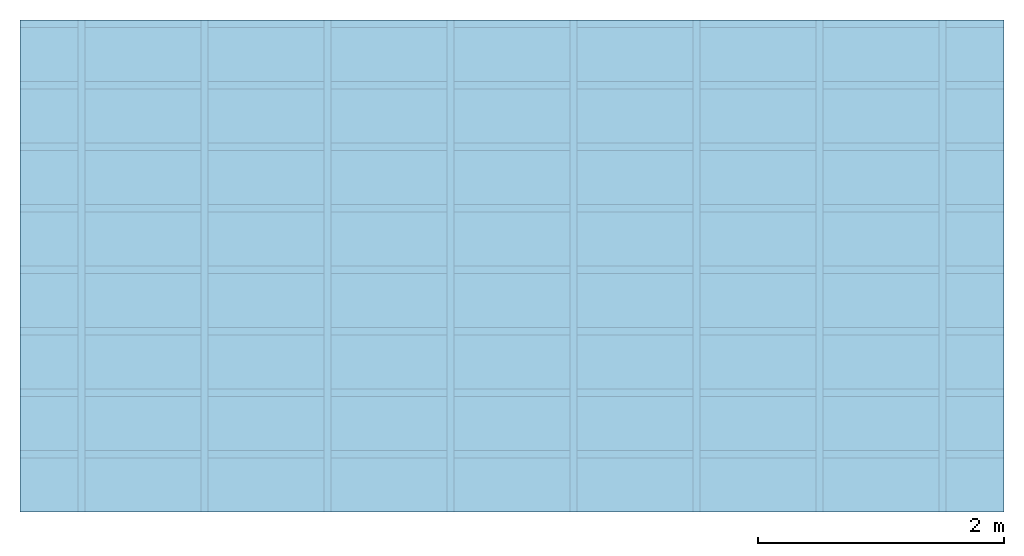
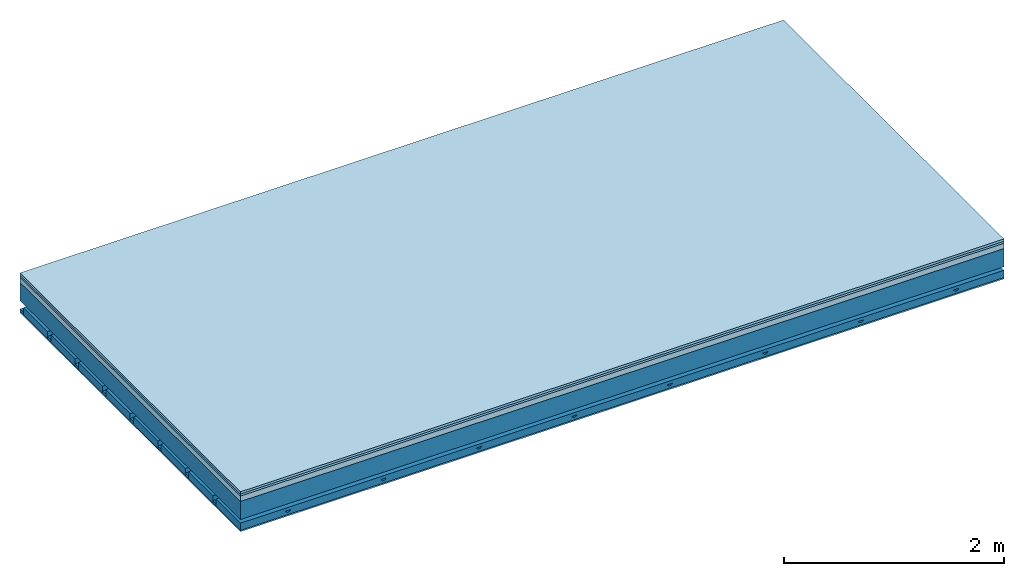
# One storey: 4 members, 4 plates, 1 element without a shape of its own.
"""IFC4 building model written with IfcOpenShell, lengths in metres."""

from ifc_helpers import new_model, si_unit, derived_unit, direction, frame, frame_2d, origin, origin_with_axes, place, context, project, spatial, polyline, rectangle, outline, extrude, material, layer, layer_set, type_object, element, aggregate, save


model = new_model("IFC4")

# Units and contexts
plan_context = context("Plan", 3, precision=1e-05, world=origin(), true_north=direction((0.0, 1.0)))
model_context = context("Model", 3, precision=1e-05, world=origin(), true_north=direction((0.0, 1.0)))
ifc_project = project(units=[si_unit("LENGTHUNIT", "METRE"), derived_unit("SOUNDPRESSUREUNIT", [(si_unit("PRESSUREUNIT", "PASCAL", prefix="MICRO"), 0)]), si_unit("ENERGYUNIT", "JOULE", prefix="MEGA"), si_unit("MASSUNIT", "GRAM", prefix="KILO"), derived_unit("THERMALTRANSMITTANCEUNIT", [(si_unit("POWERUNIT", "WATT"), 1), (si_unit("AREAUNIT", "SQUARE_METRE"), -1), (si_unit("THERMODYNAMICTEMPERATUREUNIT", "KELVIN"), -1)]), derived_unit("AREADENSITYUNIT", [(si_unit("MASSUNIT", "GRAM", prefix="KILO"), 1), (si_unit("AREAUNIT", "SQUARE_METRE"), -1)]), derived_unit("USERDEFINED", [(si_unit("ENERGYUNIT", "JOULE", prefix="MEGA"), 1), (si_unit("AREAUNIT", "SQUARE_METRE"), -1)])], contexts=[plan_context, model_context])

# Site, building, storey
site = spatial("IfcSite", under=ifc_project)
building_placement = place(None, origin())
building = spatial("IfcBuilding", under=site, at=building_placement)
storey_placement = place(building_placement, origin())
storey = spatial("IfcBuildingStorey", under=building, at=storey_placement)

# Slab, members, plates
ifc_material_1 = material(Name="Floor heating system Therm38 longitudinal", Category="03.007")
ifc_layer_1 = layer(ifc_material_1, 0.025, Name="On-material")
ifc_material_2 = material(Category="10.009")
ifc_layer_2 = layer(ifc_material_2, 0.022, Name="Impact sound insulation")
ifc_material_3 = material(Category="03.011")
ifc_layer_3 = layer(ifc_material_3, 0.06, Name="on Supporting structure")
ifc_layer_4 = layer(None, 0.2, Name="Supporting structure")
ifc_material_4 = material(Name="no composite action")
ifc_layer_5 = layer(ifc_material_4, 0.0, Name="Bond")
ifc_layer_6 = layer(None, 0.093, Name="Coupling")
ifc_layer_7 = layer(None, 0.027, Name="Battens / profiles")
ifc_material_5 = material(Category="03.007")
ifc_layer_8 = layer(ifc_material_5, 0.015, Name="Ceiling covering 1st layer")
ifc_material_6 = material(Name="Glued joints")
ifc_layer_9 = layer(ifc_material_6, 0.0, Name="Surface / treatment")
ifc_layer_set = layer_set([ifc_layer_1, ifc_layer_2, ifc_layer_3, ifc_layer_4, ifc_layer_5, ifc_layer_6, ifc_layer_7, ifc_layer_8, ifc_layer_9])
slab_type = type_object("IfcSlabType", Name="A1156", PredefinedType="NOTDEFINED", material=ifc_layer_set)
slab_placement = place(None, frame((0.0, 0.0, 0.0), z_axis=(0.0, 0.0, -1.0), x_axis=(1.0, 0.0, 0.0)))
slab = element("IfcSlab", 1, at=slab_placement, inside=storey, type_object=slab_type, material=ifc_layer_set, Name="Slab #1")
ifc_material_7 = material()
member_1_placement = place(slab_placement, origin())
member_1 = element("IfcMember", 2, at=member_1_placement, material=ifc_material_7, Name="Supporting structure", context=plan_context, shape_type="SweptSolid", body=[
    extrude(rectangle(XDim=1.0, YDim=0.2, at=frame_2d((0.5, 0.1), x_axis=(1.0, 0.0))), frame((0.0, 4.0, 0.107), z_axis=(0.0, -1.0, 0.0), x_axis=(1.0, 0.0, 0.0)), (0.0, 0.0, 1.0), 4.0),
    extrude(rectangle(XDim=1.0, YDim=0.2, at=frame_2d((0.5, 0.1), x_axis=(1.0, 0.0))), frame((1.0, 4.0, 0.107), z_axis=(0.0, -1.0, 0.0), x_axis=(1.0, 0.0, 0.0)), (0.0, 0.0, 1.0), 4.0),
    extrude(rectangle(XDim=1.0, YDim=0.2, at=frame_2d((0.5, 0.1), x_axis=(1.0, 0.0))), frame((2.0, 4.0, 0.107), z_axis=(0.0, -1.0, 0.0), x_axis=(1.0, 0.0, 0.0)), (0.0, 0.0, 1.0), 4.0),
    extrude(rectangle(XDim=1.0, YDim=0.2, at=frame_2d((0.5, 0.1), x_axis=(1.0, 0.0))), frame((3.0, 4.0, 0.107), z_axis=(0.0, -1.0, 0.0), x_axis=(1.0, 0.0, 0.0)), (0.0, 0.0, 1.0), 4.0),
    extrude(rectangle(XDim=1.0, YDim=0.2, at=frame_2d((0.5, 0.1), x_axis=(1.0, 0.0))), frame((4.0, 4.0, 0.107), z_axis=(0.0, -1.0, 0.0), x_axis=(1.0, 0.0, 0.0)), (0.0, 0.0, 1.0), 4.0),
    extrude(rectangle(XDim=1.0, YDim=0.2, at=frame_2d((0.5, 0.1), x_axis=(1.0, 0.0))), frame((5.0, 4.0, 0.107), z_axis=(0.0, -1.0, 0.0), x_axis=(1.0, 0.0, 0.0)), (0.0, 0.0, 1.0), 4.0),
    extrude(rectangle(XDim=1.0, YDim=0.2, at=frame_2d((0.5, 0.1), x_axis=(1.0, 0.0))), frame((6.0, 4.0, 0.107), z_axis=(0.0, -1.0, 0.0), x_axis=(1.0, 0.0, 0.0)), (0.0, 0.0, 1.0), 4.0),
    extrude(rectangle(XDim=1.0, YDim=0.2, at=frame_2d((0.5, 0.1), x_axis=(1.0, 0.0))), frame((7.0, 4.0, 0.107), z_axis=(0.0, -1.0, 0.0), x_axis=(1.0, 0.0, 0.0)), (0.0, 0.0, 1.0), 4.0),
])
ifc_material_8 = material()
member_2_placement = place(slab_placement, origin())
member_2 = element("IfcMember", 3, at=member_2_placement, material=ifc_material_8, Name="Coupling", context=plan_context, shape_type="SweptSolid", body=[
    extrude(outline(polyline([(0.0, 0.0), (0.06, 0.0), (0.04, 0.02), (0.02, 0.02), (0.0, 0.0)])), frame((0.47, 4.0, 0.38), z_axis=(0.0, -1.0, 0.0), x_axis=(1.0, 0.0, 0.0)), (0.0, 0.0, 1.0), 4.0),
    extrude(outline(polyline([(0.0, 0.0), (0.06, 0.0), (0.04, 0.02), (0.02, 0.02), (0.0, 0.0)])), frame((1.47, 4.0, 0.38), z_axis=(0.0, -1.0, 0.0), x_axis=(1.0, 0.0, 0.0)), (0.0, 0.0, 1.0), 4.0),
    extrude(outline(polyline([(0.0, 0.0), (0.06, 0.0), (0.04, 0.02), (0.02, 0.02), (0.0, 0.0)])), frame((2.47, 4.0, 0.38), z_axis=(0.0, -1.0, 0.0), x_axis=(1.0, 0.0, 0.0)), (0.0, 0.0, 1.0), 4.0),
    extrude(outline(polyline([(0.0, 0.0), (0.06, 0.0), (0.04, 0.02), (0.02, 0.02), (0.0, 0.0)])), frame((3.47, 4.0, 0.38), z_axis=(0.0, -1.0, 0.0), x_axis=(1.0, 0.0, 0.0)), (0.0, 0.0, 1.0), 4.0),
    extrude(outline(polyline([(0.0, 0.0), (0.06, 0.0), (0.04, 0.02), (0.02, 0.02), (0.0, 0.0)])), frame((4.47, 4.0, 0.38), z_axis=(0.0, -1.0, 0.0), x_axis=(1.0, 0.0, 0.0)), (0.0, 0.0, 1.0), 4.0),
    extrude(outline(polyline([(0.0, 0.0), (0.06, 0.0), (0.04, 0.02), (0.02, 0.02), (0.0, 0.0)])), frame((5.47, 4.0, 0.38), z_axis=(0.0, -1.0, 0.0), x_axis=(1.0, 0.0, 0.0)), (0.0, 0.0, 1.0), 4.0),
    extrude(outline(polyline([(0.0, 0.0), (0.06, 0.0), (0.04, 0.02), (0.02, 0.02), (0.0, 0.0)])), frame((6.47, 4.0, 0.38), z_axis=(0.0, -1.0, 0.0), x_axis=(1.0, 0.0, 0.0)), (0.0, 0.0, 1.0), 4.0),
    extrude(outline(polyline([(0.0, 0.0), (0.06, 0.0), (0.04, 0.02), (0.02, 0.02), (0.0, 0.0)])), frame((7.47, 4.0, 0.38), z_axis=(0.0, -1.0, 0.0), x_axis=(1.0, 0.0, 0.0)), (0.0, 0.0, 1.0), 4.0),
])
ifc_material_9 = material()
member_3_placement = place(slab_placement, origin())
member_3 = element("IfcMember", 4, at=member_3_placement, material=ifc_material_9, Name="Battens / profiles", context=plan_context, shape_type="SweptSolid", body=[
    extrude(rectangle(XDim=0.06, YDim=0.027, at=frame_2d((0.03, 0.0135), x_axis=(1.0, 0.0))), frame((0.0, 0.0, 0.4), z_axis=(1.0, 0.0, 0.0), x_axis=(0.0, 1.0, 0.0)), (0.0, 0.0, 1.0), 8.0),
    extrude(rectangle(XDim=0.06, YDim=0.027, at=frame_2d((0.03, 0.0135), x_axis=(1.0, 0.0))), frame((0.0, 0.5, 0.4), z_axis=(1.0, 0.0, 0.0), x_axis=(0.0, 1.0, 0.0)), (0.0, 0.0, 1.0), 8.0),
    extrude(rectangle(XDim=0.06, YDim=0.027, at=frame_2d((0.03, 0.0135), x_axis=(1.0, 0.0))), frame((0.0, 1.0, 0.4), z_axis=(1.0, 0.0, 0.0), x_axis=(0.0, 1.0, 0.0)), (0.0, 0.0, 1.0), 8.0),
    extrude(rectangle(XDim=0.06, YDim=0.027, at=frame_2d((0.03, 0.0135), x_axis=(1.0, 0.0))), frame((0.0, 1.5, 0.4), z_axis=(1.0, 0.0, 0.0), x_axis=(0.0, 1.0, 0.0)), (0.0, 0.0, 1.0), 8.0),
    extrude(rectangle(XDim=0.06, YDim=0.027, at=frame_2d((0.03, 0.0135), x_axis=(1.0, 0.0))), frame((0.0, 2.0, 0.4), z_axis=(1.0, 0.0, 0.0), x_axis=(0.0, 1.0, 0.0)), (0.0, 0.0, 1.0), 8.0),
    extrude(rectangle(XDim=0.06, YDim=0.027, at=frame_2d((0.03, 0.0135), x_axis=(1.0, 0.0))), frame((0.0, 2.5, 0.4), z_axis=(1.0, 0.0, 0.0), x_axis=(0.0, 1.0, 0.0)), (0.0, 0.0, 1.0), 8.0),
    extrude(rectangle(XDim=0.06, YDim=0.027, at=frame_2d((0.03, 0.0135), x_axis=(1.0, 0.0))), frame((0.0, 3.0, 0.4), z_axis=(1.0, 0.0, 0.0), x_axis=(0.0, 1.0, 0.0)), (0.0, 0.0, 1.0), 8.0),
    extrude(rectangle(XDim=0.06, YDim=0.027, at=frame_2d((0.03, 0.0135), x_axis=(1.0, 0.0))), frame((0.0, 3.5, 0.4), z_axis=(1.0, 0.0, 0.0), x_axis=(0.0, 1.0, 0.0)), (0.0, 0.0, 1.0), 8.0),
])
ifc_material_10 = material()
member_4_placement = place(slab_placement, origin())
member_4 = element("IfcMember", 5, at=member_4_placement, material=ifc_material_10, Name="Cavity", context=plan_context, shape_type="SweptSolid", body=[
    extrude(rectangle(XDim=0.44, YDim=0.08, at=frame_2d((0.22, 0.04), x_axis=(1.0, 0.0))), frame((0.0, 0.06, 0.347), z_axis=(1.0, 0.0, 0.0), x_axis=(0.0, 1.0, 0.0)), (0.0, 0.0, 1.0), 8.0),
    extrude(rectangle(XDim=0.44, YDim=0.08, at=frame_2d((0.22, 0.04), x_axis=(1.0, 0.0))), frame((0.0, 0.56, 0.347), z_axis=(1.0, 0.0, 0.0), x_axis=(0.0, 1.0, 0.0)), (0.0, 0.0, 1.0), 8.0),
    extrude(rectangle(XDim=0.44, YDim=0.08, at=frame_2d((0.22, 0.04), x_axis=(1.0, 0.0))), frame((0.0, 1.06, 0.347), z_axis=(1.0, 0.0, 0.0), x_axis=(0.0, 1.0, 0.0)), (0.0, 0.0, 1.0), 8.0),
    extrude(rectangle(XDim=0.44, YDim=0.08, at=frame_2d((0.22, 0.04), x_axis=(1.0, 0.0))), frame((0.0, 1.56, 0.347), z_axis=(1.0, 0.0, 0.0), x_axis=(0.0, 1.0, 0.0)), (0.0, 0.0, 1.0), 8.0),
    extrude(rectangle(XDim=0.44, YDim=0.08, at=frame_2d((0.22, 0.04), x_axis=(1.0, 0.0))), frame((0.0, 2.06, 0.347), z_axis=(1.0, 0.0, 0.0), x_axis=(0.0, 1.0, 0.0)), (0.0, 0.0, 1.0), 8.0),
    extrude(rectangle(XDim=0.44, YDim=0.08, at=frame_2d((0.22, 0.04), x_axis=(1.0, 0.0))), frame((0.0, 2.56, 0.347), z_axis=(1.0, 0.0, 0.0), x_axis=(0.0, 1.0, 0.0)), (0.0, 0.0, 1.0), 8.0),
    extrude(rectangle(XDim=0.44, YDim=0.08, at=frame_2d((0.22, 0.04), x_axis=(1.0, 0.0))), frame((0.0, 3.06, 0.347), z_axis=(1.0, 0.0, 0.0), x_axis=(0.0, 1.0, 0.0)), (0.0, 0.0, 1.0), 8.0),
    extrude(rectangle(XDim=0.44, YDim=0.08, at=frame_2d((0.22, 0.04), x_axis=(1.0, 0.0))), frame((0.0, 3.56, 0.347), z_axis=(1.0, 0.0, 0.0), x_axis=(0.0, 1.0, 0.0)), (0.0, 0.0, 1.0), 8.0),
])
plate_1_placement = place(slab_placement, origin())
plate_1 = element("IfcPlate", 6, at=plate_1_placement, material=ifc_material_1, Name="On-material", context=plan_context, shape_type="SweptSolid", body=[
    extrude(rectangle(XDim=8.0, YDim=4.0, at=frame_2d((4.0, 2.0), x_axis=(1.0, 0.0))), origin_with_axes(), (0.0, 0.0, 1.0), 0.025),
])
plate_2_placement = place(slab_placement, origin())
plate_2 = element("IfcPlate", 7, at=plate_2_placement, material=ifc_material_2, Name="Impact sound insulation", context=plan_context, shape_type="SweptSolid", body=[
    extrude(rectangle(XDim=8.0, YDim=4.0, at=frame_2d((4.0, 2.0), x_axis=(1.0, 0.0))), frame((0.0, 0.0, 0.025), z_axis=(0.0, 0.0, 1.0), x_axis=(1.0, 0.0, 0.0)), (0.0, 0.0, 1.0), 0.022),
])
plate_3_placement = place(slab_placement, origin())
plate_3 = element("IfcPlate", 8, at=plate_3_placement, material=ifc_material_3, Name="on Supporting structure", context=plan_context, shape_type="SweptSolid", body=[
    extrude(rectangle(XDim=8.0, YDim=4.0, at=frame_2d((4.0, 2.0), x_axis=(1.0, 0.0))), frame((0.0, 0.0, 0.047), z_axis=(0.0, 0.0, 1.0), x_axis=(1.0, 0.0, 0.0)), (0.0, 0.0, 1.0), 0.06),
])
plate_4_placement = place(slab_placement, origin())
plate_4 = element("IfcPlate", 9, at=plate_4_placement, material=ifc_material_5, Name="Ceiling covering 1st layer", context=plan_context, shape_type="SweptSolid", body=[
    extrude(rectangle(XDim=8.0, YDim=4.0, at=frame_2d((4.0, 2.0), x_axis=(1.0, 0.0))), frame((0.0, 0.0, 0.427), z_axis=(0.0, 0.0, 1.0), x_axis=(1.0, 0.0, 0.0)), (0.0, 0.0, 1.0), 0.015),
])
aggregate(slab, [plate_1, plate_2, plate_3, member_1, member_2, member_3, member_4, plate_4])

save(model, "model.ifc")
